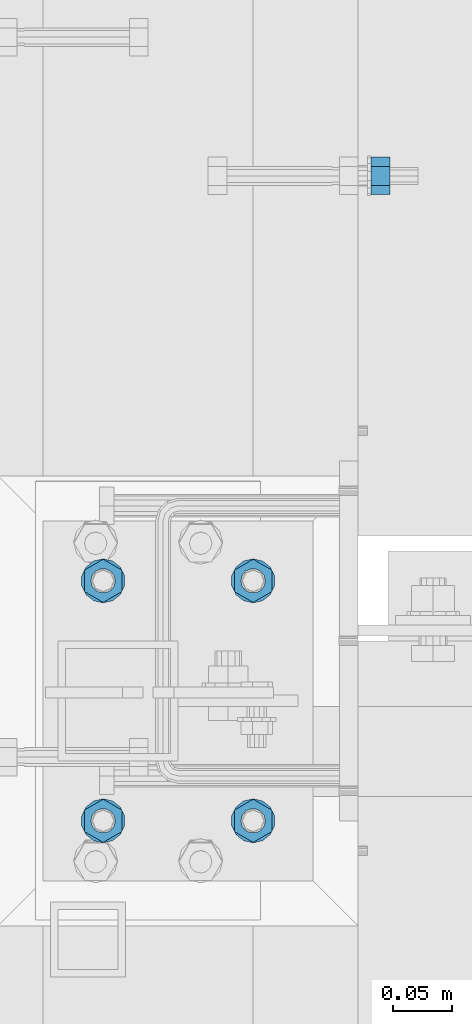
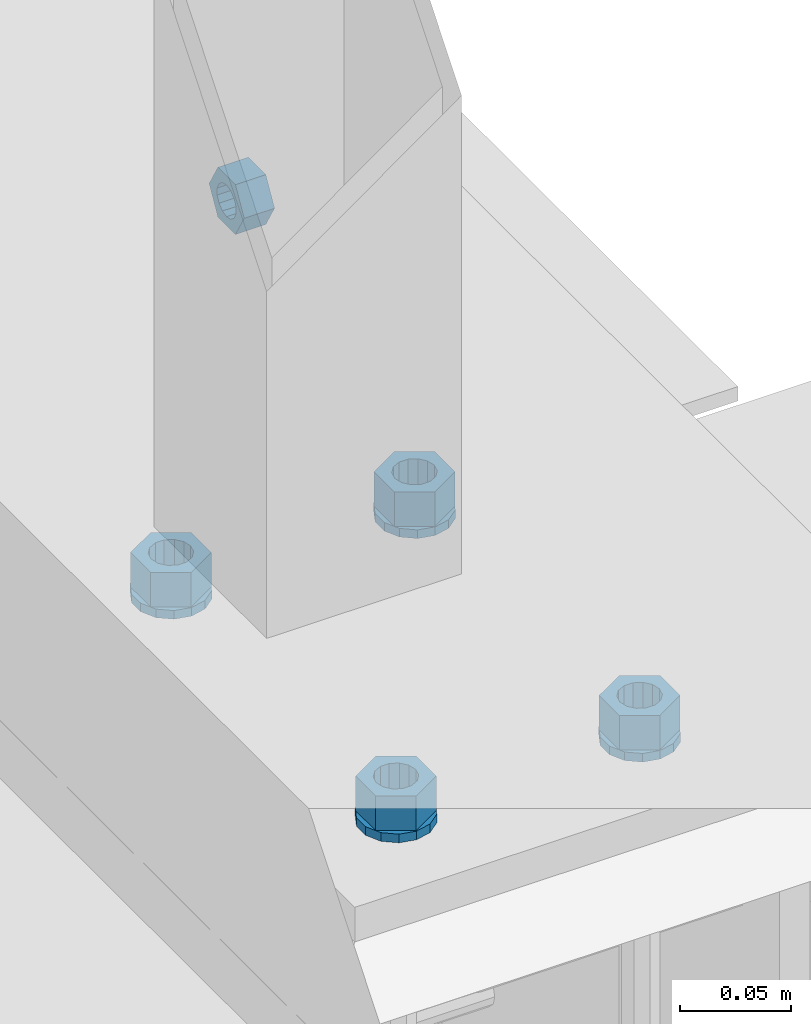
# One storey, part 562 of 975: 9 beams.
"""IFC2X3 building model written with IfcOpenShell, lengths in millimetres."""

from ifc_helpers import new_model, si_unit, frame, origin_with_axes, place, context, subcontext, project, spatial, faceted_brep, material, type_object, element, save


model = new_model("IFC2X3")

# Units and contexts
model_context = context("Model", 3, precision=1e-05, world=origin_with_axes())
body_context = subcontext(model_context, "Body", "Model", "MODEL_VIEW")
ifc_project = project(units=[si_unit("LENGTHUNIT", "METRE", prefix="MILLI"), si_unit("AREAUNIT", "SQUARE_METRE"), si_unit("VOLUMEUNIT", "CUBIC_METRE"), si_unit("MASSUNIT", "GRAM", prefix="KILO"), si_unit("TIMEUNIT", "SECOND"), si_unit("PLANEANGLEUNIT", "RADIAN"), si_unit("SOLIDANGLEUNIT", "STERADIAN"), si_unit("THERMODYNAMICTEMPERATUREUNIT", "DEGREE_CELSIUS"), si_unit("LUMINOUSINTENSITYUNIT", "LUMEN")], contexts=[model_context])

# Site, building, storey
site_placement = place(None, origin_with_axes())
site = spatial("IfcSite", under=ifc_project, at=site_placement, CompositionType="ELEMENT")
building_placement = place(site_placement, origin_with_axes())
building = spatial("IfcBuilding", under=site, at=building_placement, Name="Undefined", CompositionType="ELEMENT")
storey_placement = place(building_placement, origin_with_axes())
storey = spatial("IfcBuildingStorey", under=building, at=storey_placement, Name="Undefined", CompositionType="ELEMENT", Elevation=0.0)

# Beams
ifc_material = material(Name="STEEL/A36")
beam_type_1 = type_object("IfcBeamType", Name="5/8_HEAVY_HEX_NUT", PredefinedType="NOTDEFINED")
beam_1_placement = place(storey_placement, frame((2347.91252900035, 13785.8499761124, 3886.2), z_axis=(0.0, 0.0, -1.0), x_axis=(-0.999999999999998, 6.90000001668524e-08, 0.0)))
element("IfcBeam", 1, at=beam_1_placement, inside=storey, type_object=beam_type_1, material=ifc_material, Name="NUT", ObjectType="5/8_HEAVY_HEX_NUT", context=body_context, shape_type="Brep", body=[
    faceted_brep([(-1.09139364212751e-11, -15.8800001144436, -2.72848410531878e-12), (1.45519152283669e-11, -7.94000005722046, -13.7500000000036), (15.8750000000146, -7.94000005722137, -13.7500000000045), (15.8749999999891, -15.8800001144446, -2.72848410531878e-12), (2.91038304567337e-11, 7.94000005722319, -13.7500000000027), (15.8750000000291, 7.94000005722319, -13.7500000000027), (2.18278728425503e-11, 15.8800001144436, 9.09494701772928e-13), (15.8750000000218, 15.8800001144427, 9.09494701772928e-13), (-7.27595761418343e-12, 7.94000005722046, 13.7500000000027), (15.8749999999927, 7.94000005722046, 13.7500000000027), (-2.18278728425503e-11, -7.94000005722228, 13.7500000000009), (15.8749999999782, -7.94000005722319, 13.7500000000009), (-7.27595761418343e-12, 0.0, 8.72999954223724), (0.0, 3.78780484388062, 7.86545780435881), (15.875, 3.78780484387971, 7.86545780435881), (15.8749999999927, -9.09494701772928e-13, 8.72999954223724), (7.27595761418343e-12, 6.82538848405238, 5.44306568481716), (15.8750000000073, 6.82538848405238, 5.44306568481716), (1.09139364212751e-11, 8.51112022706275, 1.94260765157742), (15.8750000000109, 8.51112022706093, 1.94260765157651), (1.45519152283669e-11, 8.51112022706184, -1.94260765157651), (15.8750000000146, 8.51112022706184, -1.94260765157651), (2.18278728425503e-11, 6.8253884840542, -5.44306568481716), (15.8750000000218, 6.82538848405238, -5.44306568481716), (1.81898940354586e-11, 3.78780484388153, -7.86545780435881), (15.8750000000182, 3.78780484388062, -7.86545780435881), (1.81898940354586e-11, 9.09494701772928e-13, -8.72999954223997), (15.8750000000182, 9.09494701772928e-13, -8.72999954223997), (1.09139364212751e-11, -3.78780484387971, -7.86545780436063), (15.8750000000109, -3.78780484388062, -7.86545780436063), (3.63797880709171e-12, -6.82538848405238, -5.44306568481807), (15.8750000000036, -6.82538848405329, -5.44306568481807), (0.0, -8.51112022706184, -1.94260765157833), (15.875, -8.51112022706184, -1.94260765157833), (-7.27595761418343e-12, -8.51112022706184, 1.9426076515756), (15.8749999999927, -8.51112022706275, 1.9426076515756), (-1.09139364212751e-11, -6.82538848405329, 5.44306568481534), (15.8749999999927, -6.8253884840542, 5.44306568481534), (-7.27595761418343e-12, -3.78780484388062, 7.8654578043579), (15.8749999999927, -3.78780484388153, 7.8654578043579)], [[[0, 1, 2, 3]], [[1, 4, 5, 2]], [[4, 6, 7, 5]], [[6, 8, 9, 7]], [[8, 10, 11, 9]], [[10, 0, 3, 11]], [[12, 13, 14, 15]], [[13, 16, 17, 14]], [[16, 18, 19, 17]], [[18, 20, 21, 19]], [[20, 22, 23, 21]], [[22, 24, 25, 23]], [[24, 26, 27, 25]], [[26, 28, 29, 27]], [[28, 30, 31, 29]], [[30, 32, 33, 31]], [[32, 34, 35, 33]], [[34, 36, 37, 35]], [[36, 38, 39, 37]], [[38, 12, 15, 39]], [[5, 7, 9, 11, 3, 2], [17, 19, 21, 23, 25, 27, 29, 31, 33, 35, 37, 39, 15, 14]], [[10, 8, 6, 4, 1, 0], [38, 36, 34, 32, 30, 28, 26, 24, 22, 20, 18, 16, 13, 12]]]),
])
beam_type_2 = type_object("IfcBeamType", Name="3/4_WASHER", PredefinedType="NOTDEFINED")
beam_2_placement = place(storey_placement, frame((2105.025, 13442.9499998438, 3960.8125), z_axis=(1.0, 0.0, 0.0), x_axis=(0.0, 0.0, -1.0)))
element("IfcBeam", 2, at=beam_2_placement, inside=storey, type_object=beam_type_2, material=ifc_material, Name="WASHER", ObjectType="3/4_WASHER", context=body_context, shape_type="Brep", body=[
    faceted_brep([(0.0, -18.6499996185303, 0.0), (0.0, -16.8030690426876, -8.09193156902904), (4.76250000000073, -16.8030690426876, -8.09193156902904), (4.76250000000073, -18.6499996185303, 0.0), (0.0, -11.6280845668225, -14.5811568497838), (4.76250000000073, -11.6280845668225, -14.5811568497838), (0.0, -4.15001533340001, -18.1824051902857), (4.76250000000073, -4.15001533340001, -18.1824051902857), (0.0, 4.15001533340001, -18.1824051902857), (4.76250000000073, 4.15001533340001, -18.1824051902857), (0.0, 11.6280845668234, -14.5811568497838), (4.76250000000073, 11.6280845668234, -14.5811568497838), (0.0, 16.8030690426876, -8.09193156902904), (4.76250000000073, 16.8030690426876, -8.09193156902904), (0.0, 18.6499996185303, 0.0), (4.76250000000073, 18.6499996185303, 0.0), (0.0, 16.8030690426876, 8.09193156902904), (4.76250000000073, 16.8030690426876, 8.09193156902904), (0.0, 11.6280845668225, 14.5811568497838), (4.76250000000073, 11.6280845668225, 14.5811568497838), (0.0, 4.15001533340001, 18.1824051902857), (4.76250000000073, 4.15001533340001, 18.1824051902857), (0.0, -4.15001533340001, 18.1824051902857), (4.76250000000073, -4.15001533340001, 18.1824051902857), (0.0, -11.6280845668234, 14.5811568497838), (4.76250000000073, -11.6280845668234, 14.5811568497838), (0.0, -16.8030690426876, 8.09193156902904), (4.76250000000073, -16.8030690426876, 8.09193156902904), (0.0, 0.0, 10.3199996948242), (0.0, 4.47768005528269, 9.29799844179911), (4.76250000000073, 4.47768005528269, 9.29799844179911), (4.76250000000073, 0.0, 10.3199996948242), (0.0, 8.06850066047446, 6.43441456490817), (4.76250000000073, 8.06850066047446, 6.43441456490817), (0.0, 10.0612557561917, 2.29641597052117), (4.76250000000073, 10.0612557561917, 2.29641597052117), (0.0, 10.0612557561917, -2.29641597052117), (4.76250000000073, 10.0612557561917, -2.29641597052117), (0.0, 8.06850066047446, -6.43441456490814), (4.76250000000073, 8.06850066047446, -6.43441456490814), (0.0, 4.47768005528269, -9.29799844179908), (4.76250000000073, 4.47768005528269, -9.29799844179908), (0.0, 0.0, -10.3199996948242), (4.76250000000073, 0.0, -10.3199996948242), (0.0, -4.47768005528269, -9.29799844179911), (4.76250000000073, -4.47768005528269, -9.29799844179911), (0.0, -8.06850066047446, -6.43441456490817), (4.76250000000073, -8.06850066047446, -6.43441456490817), (0.0, -10.0612557561917, -2.29641597052117), (4.76250000000073, -10.0612557561917, -2.29641597052117), (0.0, -10.0612557561917, 2.29641597052117), (4.76250000000073, -10.0612557561917, 2.29641597052117), (0.0, -8.06850066047446, 6.43441456490814), (4.76250000000073, -8.06850066047446, 6.43441456490814), (0.0, -4.47768005528269, 9.29799844179908), (4.76250000000073, -4.47768005528269, 9.29799844179908)], [[[0, 1, 2, 3]], [[1, 4, 5, 2]], [[4, 6, 7, 5]], [[6, 8, 9, 7]], [[8, 10, 11, 9]], [[10, 12, 13, 11]], [[12, 14, 15, 13]], [[14, 16, 17, 15]], [[16, 18, 19, 17]], [[18, 20, 21, 19]], [[20, 22, 23, 21]], [[22, 24, 25, 23]], [[24, 26, 27, 25]], [[26, 0, 3, 27]], [[28, 29, 30, 31]], [[29, 32, 33, 30]], [[32, 34, 35, 33]], [[34, 36, 37, 35]], [[36, 38, 39, 37]], [[38, 40, 41, 39]], [[40, 42, 43, 41]], [[42, 44, 45, 43]], [[44, 46, 47, 45]], [[46, 48, 49, 47]], [[48, 50, 51, 49]], [[50, 52, 53, 51]], [[52, 54, 55, 53]], [[54, 28, 31, 55]], [[5, 7, 9, 11, 13, 15, 17, 19, 21, 23, 25, 27, 3, 2], [33, 35, 37, 39, 41, 43, 45, 47, 49, 51, 53, 55, 31, 30]], [[26, 24, 22, 20, 18, 16, 14, 12, 10, 8, 6, 4, 1, 0], [54, 52, 50, 48, 46, 44, 42, 40, 38, 36, 34, 32, 29, 28]]]),
])
beam_3_placement = place(storey_placement, frame((2105.025, 13239.7499998438, 3960.8125), z_axis=(1.0, 0.0, 0.0), x_axis=(0.0, 0.0, -1.0)))
element("IfcBeam", 3, at=beam_3_placement, inside=storey, type_object=beam_type_2, material=ifc_material, Name="WASHER", ObjectType="3/4_WASHER", context=body_context, shape_type="Brep", body=[
    faceted_brep([(0.0, -18.6499996185303, 0.0), (0.0, -16.8030690426876, -8.09193156902904), (4.76250000000073, -16.8030690426876, -8.09193156902904), (4.76250000000073, -18.6499996185303, 0.0), (0.0, -11.6280845668225, -14.5811568497838), (4.76250000000073, -11.6280845668225, -14.5811568497838), (0.0, -4.15001533340001, -18.1824051902857), (4.76250000000073, -4.15001533340001, -18.1824051902857), (0.0, 4.15001533340001, -18.1824051902857), (4.76250000000073, 4.15001533340001, -18.1824051902857), (0.0, 11.6280845668234, -14.5811568497838), (4.76250000000073, 11.6280845668234, -14.5811568497838), (0.0, 16.8030690426876, -8.09193156902904), (4.76250000000073, 16.8030690426876, -8.09193156902904), (0.0, 18.6499996185303, 0.0), (4.76250000000073, 18.6499996185303, 0.0), (0.0, 16.8030690426876, 8.09193156902904), (4.76250000000073, 16.8030690426876, 8.09193156902904), (0.0, 11.6280845668225, 14.5811568497838), (4.76250000000073, 11.6280845668225, 14.5811568497838), (0.0, 4.15001533340001, 18.1824051902857), (4.76250000000073, 4.15001533340001, 18.1824051902857), (0.0, -4.15001533340001, 18.1824051902857), (4.76250000000073, -4.15001533340001, 18.1824051902857), (0.0, -11.6280845668234, 14.5811568497838), (4.76250000000073, -11.6280845668234, 14.5811568497838), (0.0, -16.8030690426876, 8.09193156902904), (4.76250000000073, -16.8030690426876, 8.09193156902904), (0.0, 0.0, 10.3199996948242), (0.0, 4.47768005528269, 9.29799844179911), (4.76250000000073, 4.47768005528269, 9.29799844179911), (4.76250000000073, 0.0, 10.3199996948242), (0.0, 8.06850066047446, 6.43441456490817), (4.76250000000073, 8.06850066047446, 6.43441456490817), (0.0, 10.0612557561917, 2.29641597052117), (4.76250000000073, 10.0612557561917, 2.29641597052117), (0.0, 10.0612557561917, -2.29641597052117), (4.76250000000073, 10.0612557561917, -2.29641597052117), (0.0, 8.06850066047446, -6.43441456490814), (4.76250000000073, 8.06850066047446, -6.43441456490814), (0.0, 4.47768005528269, -9.29799844179908), (4.76250000000073, 4.47768005528269, -9.29799844179908), (0.0, 0.0, -10.3199996948242), (4.76250000000073, 0.0, -10.3199996948242), (0.0, -4.47768005528269, -9.29799844179911), (4.76250000000073, -4.47768005528269, -9.29799844179911), (0.0, -8.06850066047446, -6.43441456490817), (4.76250000000073, -8.06850066047446, -6.43441456490817), (0.0, -10.0612557561917, -2.29641597052117), (4.76250000000073, -10.0612557561917, -2.29641597052117), (0.0, -10.0612557561917, 2.29641597052117), (4.76250000000073, -10.0612557561917, 2.29641597052117), (0.0, -8.06850066047446, 6.43441456490814), (4.76250000000073, -8.06850066047446, 6.43441456490814), (0.0, -4.47768005528269, 9.29799844179908), (4.76250000000073, -4.47768005528269, 9.29799844179908)], [[[0, 1, 2, 3]], [[1, 4, 5, 2]], [[4, 6, 7, 5]], [[6, 8, 9, 7]], [[8, 10, 11, 9]], [[10, 12, 13, 11]], [[12, 14, 15, 13]], [[14, 16, 17, 15]], [[16, 18, 19, 17]], [[18, 20, 21, 19]], [[20, 22, 23, 21]], [[22, 24, 25, 23]], [[24, 26, 27, 25]], [[26, 0, 3, 27]], [[28, 29, 30, 31]], [[29, 32, 33, 30]], [[32, 34, 35, 33]], [[34, 36, 37, 35]], [[36, 38, 39, 37]], [[38, 40, 41, 39]], [[40, 42, 43, 41]], [[42, 44, 45, 43]], [[44, 46, 47, 45]], [[46, 48, 49, 47]], [[48, 50, 51, 49]], [[50, 52, 53, 51]], [[52, 54, 55, 53]], [[54, 28, 31, 55]], [[5, 7, 9, 11, 13, 15, 17, 19, 21, 23, 25, 27, 3, 2], [33, 35, 37, 39, 41, 43, 45, 47, 49, 51, 53, 55, 31, 30]], [[26, 24, 22, 20, 18, 16, 14, 12, 10, 8, 6, 4, 1, 0], [54, 52, 50, 48, 46, 44, 42, 40, 38, 36, 34, 32, 29, 28]]]),
])
beam_4_placement = place(storey_placement, frame((2232.0249962741, 13442.9499998438, 3960.8125), z_axis=(1.0, 0.0, 0.0), x_axis=(0.0, 0.0, -1.0)))
element("IfcBeam", 4, at=beam_4_placement, inside=storey, type_object=beam_type_2, material=ifc_material, Name="WASHER", ObjectType="3/4_WASHER", context=body_context, shape_type="Brep", body=[
    faceted_brep([(0.0, -18.6499996185303, 0.0), (0.0, -16.8030690426876, -8.09193156902904), (4.76250000000073, -16.8030690426876, -8.09193156902904), (4.76250000000073, -18.6499996185303, 0.0), (0.0, -11.6280845668225, -14.5811568497838), (4.76250000000073, -11.6280845668225, -14.5811568497838), (0.0, -4.15001533340001, -18.1824051902857), (4.76250000000073, -4.15001533340001, -18.1824051902857), (0.0, 4.15001533340001, -18.1824051902857), (4.76250000000073, 4.15001533340001, -18.1824051902857), (0.0, 11.6280845668234, -14.5811568497838), (4.76250000000073, 11.6280845668234, -14.5811568497838), (0.0, 16.8030690426876, -8.09193156902904), (4.76250000000073, 16.8030690426876, -8.09193156902904), (0.0, 18.6499996185303, 0.0), (4.76250000000073, 18.6499996185303, 0.0), (0.0, 16.8030690426876, 8.09193156902904), (4.76250000000073, 16.8030690426876, 8.09193156902904), (0.0, 11.6280845668225, 14.5811568497838), (4.76250000000073, 11.6280845668225, 14.5811568497838), (0.0, 4.15001533340001, 18.1824051902857), (4.76250000000073, 4.15001533340001, 18.1824051902857), (0.0, -4.15001533340001, 18.1824051902857), (4.76250000000073, -4.15001533340001, 18.1824051902857), (0.0, -11.6280845668234, 14.5811568497838), (4.76250000000073, -11.6280845668234, 14.5811568497838), (0.0, -16.8030690426876, 8.09193156902904), (4.76250000000073, -16.8030690426876, 8.09193156902904), (0.0, 0.0, 10.3199996948242), (0.0, 4.47768005528269, 9.29799844179911), (4.76250000000073, 4.47768005528269, 9.29799844179911), (4.76250000000073, 0.0, 10.3199996948242), (0.0, 8.06850066047446, 6.43441456490817), (4.76250000000073, 8.06850066047446, 6.43441456490817), (0.0, 10.0612557561917, 2.29641597052117), (4.76250000000073, 10.0612557561917, 2.29641597052117), (0.0, 10.0612557561917, -2.29641597052117), (4.76250000000073, 10.0612557561917, -2.29641597052117), (0.0, 8.06850066047446, -6.43441456490814), (4.76250000000073, 8.06850066047446, -6.43441456490814), (0.0, 4.47768005528269, -9.29799844179908), (4.76250000000073, 4.47768005528269, -9.29799844179908), (0.0, 0.0, -10.3199996948242), (4.76250000000073, 0.0, -10.3199996948242), (0.0, -4.47768005528269, -9.29799844179911), (4.76250000000073, -4.47768005528269, -9.29799844179911), (0.0, -8.06850066047446, -6.43441456490817), (4.76250000000073, -8.06850066047446, -6.43441456490817), (0.0, -10.0612557561917, -2.29641597052117), (4.76250000000073, -10.0612557561917, -2.29641597052117), (0.0, -10.0612557561917, 2.29641597052117), (4.76250000000073, -10.0612557561917, 2.29641597052117), (0.0, -8.06850066047446, 6.43441456490814), (4.76250000000073, -8.06850066047446, 6.43441456490814), (0.0, -4.47768005528269, 9.29799844179908), (4.76250000000073, -4.47768005528269, 9.29799844179908)], [[[0, 1, 2, 3]], [[1, 4, 5, 2]], [[4, 6, 7, 5]], [[6, 8, 9, 7]], [[8, 10, 11, 9]], [[10, 12, 13, 11]], [[12, 14, 15, 13]], [[14, 16, 17, 15]], [[16, 18, 19, 17]], [[18, 20, 21, 19]], [[20, 22, 23, 21]], [[22, 24, 25, 23]], [[24, 26, 27, 25]], [[26, 0, 3, 27]], [[28, 29, 30, 31]], [[29, 32, 33, 30]], [[32, 34, 35, 33]], [[34, 36, 37, 35]], [[36, 38, 39, 37]], [[38, 40, 41, 39]], [[40, 42, 43, 41]], [[42, 44, 45, 43]], [[44, 46, 47, 45]], [[46, 48, 49, 47]], [[48, 50, 51, 49]], [[50, 52, 53, 51]], [[52, 54, 55, 53]], [[54, 28, 31, 55]], [[5, 7, 9, 11, 13, 15, 17, 19, 21, 23, 25, 27, 3, 2], [33, 35, 37, 39, 41, 43, 45, 47, 49, 51, 53, 55, 31, 30]], [[26, 24, 22, 20, 18, 16, 14, 12, 10, 8, 6, 4, 1, 0], [54, 52, 50, 48, 46, 44, 42, 40, 38, 36, 34, 32, 29, 28]]]),
])
beam_5_placement = place(storey_placement, frame((2232.0249962741, 13239.7499998438, 3960.8125), z_axis=(1.0, 0.0, 0.0), x_axis=(0.0, 0.0, -1.0)))
element("IfcBeam", 5, at=beam_5_placement, inside=storey, type_object=beam_type_2, material=ifc_material, Name="WASHER", ObjectType="3/4_WASHER", context=body_context, shape_type="Brep", body=[
    faceted_brep([(0.0, -18.6499996185303, 0.0), (0.0, -16.8030690426876, -8.09193156902904), (4.76250000000073, -16.8030690426876, -8.09193156902904), (4.76250000000073, -18.6499996185303, 0.0), (0.0, -11.6280845668225, -14.5811568497838), (4.76250000000073, -11.6280845668225, -14.5811568497838), (0.0, -4.15001533340001, -18.1824051902857), (4.76250000000073, -4.15001533340001, -18.1824051902857), (0.0, 4.15001533340001, -18.1824051902857), (4.76250000000073, 4.15001533340001, -18.1824051902857), (0.0, 11.6280845668234, -14.5811568497838), (4.76250000000073, 11.6280845668234, -14.5811568497838), (0.0, 16.8030690426876, -8.09193156902904), (4.76250000000073, 16.8030690426876, -8.09193156902904), (0.0, 18.6499996185303, 0.0), (4.76250000000073, 18.6499996185303, 0.0), (0.0, 16.8030690426876, 8.09193156902904), (4.76250000000073, 16.8030690426876, 8.09193156902904), (0.0, 11.6280845668225, 14.5811568497838), (4.76250000000073, 11.6280845668225, 14.5811568497838), (0.0, 4.15001533340001, 18.1824051902857), (4.76250000000073, 4.15001533340001, 18.1824051902857), (0.0, -4.15001533340001, 18.1824051902857), (4.76250000000073, -4.15001533340001, 18.1824051902857), (0.0, -11.6280845668234, 14.5811568497838), (4.76250000000073, -11.6280845668234, 14.5811568497838), (0.0, -16.8030690426876, 8.09193156902904), (4.76250000000073, -16.8030690426876, 8.09193156902904), (0.0, 0.0, 10.3199996948242), (0.0, 4.47768005528269, 9.29799844179911), (4.76250000000073, 4.47768005528269, 9.29799844179911), (4.76250000000073, 0.0, 10.3199996948242), (0.0, 8.06850066047446, 6.43441456490817), (4.76250000000073, 8.06850066047446, 6.43441456490817), (0.0, 10.0612557561917, 2.29641597052117), (4.76250000000073, 10.0612557561917, 2.29641597052117), (0.0, 10.0612557561917, -2.29641597052117), (4.76250000000073, 10.0612557561917, -2.29641597052117), (0.0, 8.06850066047446, -6.43441456490814), (4.76250000000073, 8.06850066047446, -6.43441456490814), (0.0, 4.47768005528269, -9.29799844179908), (4.76250000000073, 4.47768005528269, -9.29799844179908), (0.0, 0.0, -10.3199996948242), (4.76250000000073, 0.0, -10.3199996948242), (0.0, -4.47768005528269, -9.29799844179911), (4.76250000000073, -4.47768005528269, -9.29799844179911), (0.0, -8.06850066047446, -6.43441456490817), (4.76250000000073, -8.06850066047446, -6.43441456490817), (0.0, -10.0612557561917, -2.29641597052117), (4.76250000000073, -10.0612557561917, -2.29641597052117), (0.0, -10.0612557561917, 2.29641597052117), (4.76250000000073, -10.0612557561917, 2.29641597052117), (0.0, -8.06850066047446, 6.43441456490814), (4.76250000000073, -8.06850066047446, 6.43441456490814), (0.0, -4.47768005528269, 9.29799844179908), (4.76250000000073, -4.47768005528269, 9.29799844179908)], [[[0, 1, 2, 3]], [[1, 4, 5, 2]], [[4, 6, 7, 5]], [[6, 8, 9, 7]], [[8, 10, 11, 9]], [[10, 12, 13, 11]], [[12, 14, 15, 13]], [[14, 16, 17, 15]], [[16, 18, 19, 17]], [[18, 20, 21, 19]], [[20, 22, 23, 21]], [[22, 24, 25, 23]], [[24, 26, 27, 25]], [[26, 0, 3, 27]], [[28, 29, 30, 31]], [[29, 32, 33, 30]], [[32, 34, 35, 33]], [[34, 36, 37, 35]], [[36, 38, 39, 37]], [[38, 40, 41, 39]], [[40, 42, 43, 41]], [[42, 44, 45, 43]], [[44, 46, 47, 45]], [[46, 48, 49, 47]], [[48, 50, 51, 49]], [[50, 52, 53, 51]], [[52, 54, 55, 53]], [[54, 28, 31, 55]], [[5, 7, 9, 11, 13, 15, 17, 19, 21, 23, 25, 27, 3, 2], [33, 35, 37, 39, 41, 43, 45, 47, 49, 51, 53, 55, 31, 30]], [[26, 24, 22, 20, 18, 16, 14, 12, 10, 8, 6, 4, 1, 0], [54, 52, 50, 48, 46, 44, 42, 40, 38, 36, 34, 32, 29, 28]]]),
])
beam_type_3 = type_object("IfcBeamType", Name="3/4_HEAVY_HEX_NUT", PredefinedType="NOTDEFINED")
beam_6_placement = place(storey_placement, frame((2105.025, 13442.9499998438, 3979.8625), z_axis=(1.0, 0.0, 0.0), x_axis=(0.0, 0.0, -1.0)))
element("IfcBeam", 6, at=beam_6_placement, inside=storey, type_object=beam_type_3, material=ifc_material, Name="NUT", ObjectType="3/4_HEAVY_HEX_NUT", context=body_context, shape_type="Brep", body=[
    faceted_brep([(0.0, -18.2600002288818, 0.0), (0.0, -9.13000011444092, -15.8100004196167), (19.0499999999993, -9.13000011444092, -15.8100004196167), (19.0499999999993, -18.2600002288818, 0.0), (0.0, 9.13000011444092, -15.8100004196167), (19.0499999999993, 9.13000011444092, -15.8100004196167), (0.0, 18.2600002288818, 0.0), (19.0499999999993, 18.2600002288818, 0.0), (0.0, 9.13000011444092, 15.8100004196167), (19.0499999999993, 9.13000011444092, 15.8100004196167), (0.0, -9.13000011444092, 15.8100004196167), (19.0499999999993, -9.13000011444092, 15.8100004196167), (0.0, 0.0, 10.3199996948242), (0.0, 4.47768005528269, 9.29799844179911), (19.0499999999993, 4.47768005528269, 9.29799844179911), (19.0499999999993, 0.0, 10.3199996948242), (0.0, 8.06850066047446, 6.43441456490817), (19.0499999999993, 8.06850066047446, 6.43441456490817), (0.0, 10.0612557561917, 2.29641597052117), (19.0499999999993, 10.0612557561917, 2.29641597052117), (0.0, 10.0612557561917, -2.29641597052117), (19.0499999999993, 10.0612557561917, -2.29641597052117), (0.0, 8.06850066047446, -6.43441456490814), (19.0499999999993, 8.06850066047446, -6.43441456490814), (0.0, 4.47768005528269, -9.29799844179908), (19.0499999999993, 4.47768005528269, -9.29799844179908), (0.0, 0.0, -10.3199996948242), (19.0499999999993, 0.0, -10.3199996948242), (0.0, -4.47768005528269, -9.29799844179911), (19.0499999999993, -4.47768005528269, -9.29799844179911), (0.0, -8.06850066047446, -6.43441456490817), (19.0499999999993, -8.06850066047446, -6.43441456490817), (0.0, -10.0612557561917, -2.29641597052117), (19.0499999999993, -10.0612557561917, -2.29641597052117), (0.0, -10.0612557561917, 2.29641597052117), (19.0499999999993, -10.0612557561917, 2.29641597052117), (0.0, -8.06850066047446, 6.43441456490814), (19.0499999999993, -8.06850066047446, 6.43441456490814), (0.0, -4.47768005528269, 9.29799844179908), (19.0499999999993, -4.47768005528269, 9.29799844179908)], [[[0, 1, 2, 3]], [[1, 4, 5, 2]], [[4, 6, 7, 5]], [[6, 8, 9, 7]], [[8, 10, 11, 9]], [[10, 0, 3, 11]], [[12, 13, 14, 15]], [[13, 16, 17, 14]], [[16, 18, 19, 17]], [[18, 20, 21, 19]], [[20, 22, 23, 21]], [[22, 24, 25, 23]], [[24, 26, 27, 25]], [[26, 28, 29, 27]], [[28, 30, 31, 29]], [[30, 32, 33, 31]], [[32, 34, 35, 33]], [[34, 36, 37, 35]], [[36, 38, 39, 37]], [[38, 12, 15, 39]], [[5, 7, 9, 11, 3, 2], [17, 19, 21, 23, 25, 27, 29, 31, 33, 35, 37, 39, 15, 14]], [[10, 8, 6, 4, 1, 0], [38, 36, 34, 32, 30, 28, 26, 24, 22, 20, 18, 16, 13, 12]]]),
])
beam_7_placement = place(storey_placement, frame((2105.025, 13239.7499998438, 3979.8625), z_axis=(1.0, 0.0, 0.0), x_axis=(0.0, 0.0, -1.0)))
element("IfcBeam", 7, at=beam_7_placement, inside=storey, type_object=beam_type_3, material=ifc_material, Name="NUT", ObjectType="3/4_HEAVY_HEX_NUT", context=body_context, shape_type="Brep", body=[
    faceted_brep([(0.0, -18.2600002288818, 0.0), (0.0, -9.13000011444092, -15.8100004196167), (19.0499999999993, -9.13000011444092, -15.8100004196167), (19.0499999999993, -18.2600002288818, 0.0), (0.0, 9.13000011444092, -15.8100004196167), (19.0499999999993, 9.13000011444092, -15.8100004196167), (0.0, 18.2600002288818, 0.0), (19.0499999999993, 18.2600002288818, 0.0), (0.0, 9.13000011444092, 15.8100004196167), (19.0499999999993, 9.13000011444092, 15.8100004196167), (0.0, -9.13000011444092, 15.8100004196167), (19.0499999999993, -9.13000011444092, 15.8100004196167), (0.0, 0.0, 10.3199996948242), (0.0, 4.47768005528269, 9.29799844179911), (19.0499999999993, 4.47768005528269, 9.29799844179911), (19.0499999999993, 0.0, 10.3199996948242), (0.0, 8.06850066047446, 6.43441456490817), (19.0499999999993, 8.06850066047446, 6.43441456490817), (0.0, 10.0612557561917, 2.29641597052117), (19.0499999999993, 10.0612557561917, 2.29641597052117), (0.0, 10.0612557561917, -2.29641597052117), (19.0499999999993, 10.0612557561917, -2.29641597052117), (0.0, 8.06850066047446, -6.43441456490814), (19.0499999999993, 8.06850066047446, -6.43441456490814), (0.0, 4.47768005528269, -9.29799844179908), (19.0499999999993, 4.47768005528269, -9.29799844179908), (0.0, 0.0, -10.3199996948242), (19.0499999999993, 0.0, -10.3199996948242), (0.0, -4.47768005528269, -9.29799844179911), (19.0499999999993, -4.47768005528269, -9.29799844179911), (0.0, -8.06850066047446, -6.43441456490817), (19.0499999999993, -8.06850066047446, -6.43441456490817), (0.0, -10.0612557561917, -2.29641597052117), (19.0499999999993, -10.0612557561917, -2.29641597052117), (0.0, -10.0612557561917, 2.29641597052117), (19.0499999999993, -10.0612557561917, 2.29641597052117), (0.0, -8.06850066047446, 6.43441456490814), (19.0499999999993, -8.06850066047446, 6.43441456490814), (0.0, -4.47768005528269, 9.29799844179908), (19.0499999999993, -4.47768005528269, 9.29799844179908)], [[[0, 1, 2, 3]], [[1, 4, 5, 2]], [[4, 6, 7, 5]], [[6, 8, 9, 7]], [[8, 10, 11, 9]], [[10, 0, 3, 11]], [[12, 13, 14, 15]], [[13, 16, 17, 14]], [[16, 18, 19, 17]], [[18, 20, 21, 19]], [[20, 22, 23, 21]], [[22, 24, 25, 23]], [[24, 26, 27, 25]], [[26, 28, 29, 27]], [[28, 30, 31, 29]], [[30, 32, 33, 31]], [[32, 34, 35, 33]], [[34, 36, 37, 35]], [[36, 38, 39, 37]], [[38, 12, 15, 39]], [[5, 7, 9, 11, 3, 2], [17, 19, 21, 23, 25, 27, 29, 31, 33, 35, 37, 39, 15, 14]], [[10, 8, 6, 4, 1, 0], [38, 36, 34, 32, 30, 28, 26, 24, 22, 20, 18, 16, 13, 12]]]),
])
beam_8_placement = place(storey_placement, frame((2232.0249962741, 13442.9499998438, 3979.8625), z_axis=(1.0, 0.0, 0.0), x_axis=(0.0, 0.0, -1.0)))
element("IfcBeam", 8, at=beam_8_placement, inside=storey, type_object=beam_type_3, material=ifc_material, Name="NUT", ObjectType="3/4_HEAVY_HEX_NUT", context=body_context, shape_type="Brep", body=[
    faceted_brep([(0.0, -18.2600002288818, 0.0), (0.0, -9.13000011444092, -15.8100004196167), (19.0499999999993, -9.13000011444092, -15.8100004196167), (19.0499999999993, -18.2600002288818, 0.0), (0.0, 9.13000011444092, -15.8100004196167), (19.0499999999993, 9.13000011444092, -15.8100004196167), (0.0, 18.2600002288818, 0.0), (19.0499999999993, 18.2600002288818, 0.0), (0.0, 9.13000011444092, 15.8100004196167), (19.0499999999993, 9.13000011444092, 15.8100004196167), (0.0, -9.13000011444092, 15.8100004196167), (19.0499999999993, -9.13000011444092, 15.8100004196167), (0.0, 0.0, 10.3199996948242), (0.0, 4.47768005528269, 9.29799844179911), (19.0499999999993, 4.47768005528269, 9.29799844179911), (19.0499999999993, 0.0, 10.3199996948242), (0.0, 8.06850066047446, 6.43441456490817), (19.0499999999993, 8.06850066047446, 6.43441456490817), (0.0, 10.0612557561917, 2.29641597052117), (19.0499999999993, 10.0612557561917, 2.29641597052117), (0.0, 10.0612557561917, -2.29641597052117), (19.0499999999993, 10.0612557561917, -2.29641597052117), (0.0, 8.06850066047446, -6.43441456490814), (19.0499999999993, 8.06850066047446, -6.43441456490814), (0.0, 4.47768005528269, -9.29799844179908), (19.0499999999993, 4.47768005528269, -9.29799844179908), (0.0, 0.0, -10.3199996948242), (19.0499999999993, 0.0, -10.3199996948242), (0.0, -4.47768005528269, -9.29799844179911), (19.0499999999993, -4.47768005528269, -9.29799844179911), (0.0, -8.06850066047446, -6.43441456490817), (19.0499999999993, -8.06850066047446, -6.43441456490817), (0.0, -10.0612557561917, -2.29641597052117), (19.0499999999993, -10.0612557561917, -2.29641597052117), (0.0, -10.0612557561917, 2.29641597052117), (19.0499999999993, -10.0612557561917, 2.29641597052117), (0.0, -8.06850066047446, 6.43441456490814), (19.0499999999993, -8.06850066047446, 6.43441456490814), (0.0, -4.47768005528269, 9.29799844179908), (19.0499999999993, -4.47768005528269, 9.29799844179908)], [[[0, 1, 2, 3]], [[1, 4, 5, 2]], [[4, 6, 7, 5]], [[6, 8, 9, 7]], [[8, 10, 11, 9]], [[10, 0, 3, 11]], [[12, 13, 14, 15]], [[13, 16, 17, 14]], [[16, 18, 19, 17]], [[18, 20, 21, 19]], [[20, 22, 23, 21]], [[22, 24, 25, 23]], [[24, 26, 27, 25]], [[26, 28, 29, 27]], [[28, 30, 31, 29]], [[30, 32, 33, 31]], [[32, 34, 35, 33]], [[34, 36, 37, 35]], [[36, 38, 39, 37]], [[38, 12, 15, 39]], [[5, 7, 9, 11, 3, 2], [17, 19, 21, 23, 25, 27, 29, 31, 33, 35, 37, 39, 15, 14]], [[10, 8, 6, 4, 1, 0], [38, 36, 34, 32, 30, 28, 26, 24, 22, 20, 18, 16, 13, 12]]]),
])
beam_9_placement = place(storey_placement, frame((2232.0249962741, 13239.7499998438, 3979.8625), z_axis=(1.0, 0.0, 0.0), x_axis=(0.0, 0.0, -1.0)))
element("IfcBeam", 9, at=beam_9_placement, inside=storey, type_object=beam_type_3, material=ifc_material, Name="NUT", ObjectType="3/4_HEAVY_HEX_NUT", context=body_context, shape_type="Brep", body=[
    faceted_brep([(0.0, -18.2600002288818, 0.0), (0.0, -9.13000011444092, -15.8100004196167), (19.0499999999993, -9.13000011444092, -15.8100004196167), (19.0499999999993, -18.2600002288818, 0.0), (0.0, 9.13000011444092, -15.8100004196167), (19.0499999999993, 9.13000011444092, -15.8100004196167), (0.0, 18.2600002288818, 0.0), (19.0499999999993, 18.2600002288818, 0.0), (0.0, 9.13000011444092, 15.8100004196167), (19.0499999999993, 9.13000011444092, 15.8100004196167), (0.0, -9.13000011444092, 15.8100004196167), (19.0499999999993, -9.13000011444092, 15.8100004196167), (0.0, 0.0, 10.3199996948242), (0.0, 4.47768005528269, 9.29799844179911), (19.0499999999993, 4.47768005528269, 9.29799844179911), (19.0499999999993, 0.0, 10.3199996948242), (0.0, 8.06850066047446, 6.43441456490817), (19.0499999999993, 8.06850066047446, 6.43441456490817), (0.0, 10.0612557561917, 2.29641597052117), (19.0499999999993, 10.0612557561917, 2.29641597052117), (0.0, 10.0612557561917, -2.29641597052117), (19.0499999999993, 10.0612557561917, -2.29641597052117), (0.0, 8.06850066047446, -6.43441456490814), (19.0499999999993, 8.06850066047446, -6.43441456490814), (0.0, 4.47768005528269, -9.29799844179908), (19.0499999999993, 4.47768005528269, -9.29799844179908), (0.0, 0.0, -10.3199996948242), (19.0499999999993, 0.0, -10.3199996948242), (0.0, -4.47768005528269, -9.29799844179911), (19.0499999999993, -4.47768005528269, -9.29799844179911), (0.0, -8.06850066047446, -6.43441456490817), (19.0499999999993, -8.06850066047446, -6.43441456490817), (0.0, -10.0612557561917, -2.29641597052117), (19.0499999999993, -10.0612557561917, -2.29641597052117), (0.0, -10.0612557561917, 2.29641597052117), (19.0499999999993, -10.0612557561917, 2.29641597052117), (0.0, -8.06850066047446, 6.43441456490814), (19.0499999999993, -8.06850066047446, 6.43441456490814), (0.0, -4.47768005528269, 9.29799844179908), (19.0499999999993, -4.47768005528269, 9.29799844179908)], [[[0, 1, 2, 3]], [[1, 4, 5, 2]], [[4, 6, 7, 5]], [[6, 8, 9, 7]], [[8, 10, 11, 9]], [[10, 0, 3, 11]], [[12, 13, 14, 15]], [[13, 16, 17, 14]], [[16, 18, 19, 17]], [[18, 20, 21, 19]], [[20, 22, 23, 21]], [[22, 24, 25, 23]], [[24, 26, 27, 25]], [[26, 28, 29, 27]], [[28, 30, 31, 29]], [[30, 32, 33, 31]], [[32, 34, 35, 33]], [[34, 36, 37, 35]], [[36, 38, 39, 37]], [[38, 12, 15, 39]], [[5, 7, 9, 11, 3, 2], [17, 19, 21, 23, 25, 27, 29, 31, 33, 35, 37, 39, 15, 14]], [[10, 8, 6, 4, 1, 0], [38, 36, 34, 32, 30, 28, 26, 24, 22, 20, 18, 16, 13, 12]]]),
])

save(model, "model.ifc")
